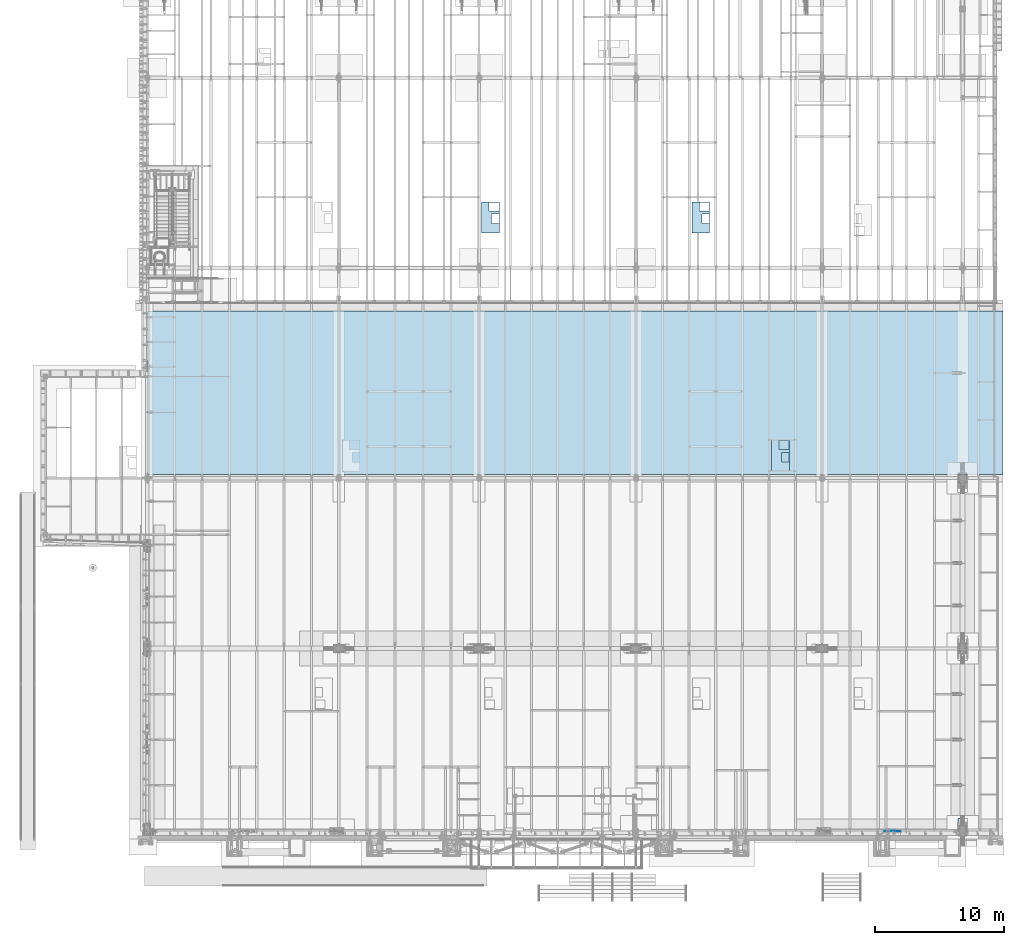
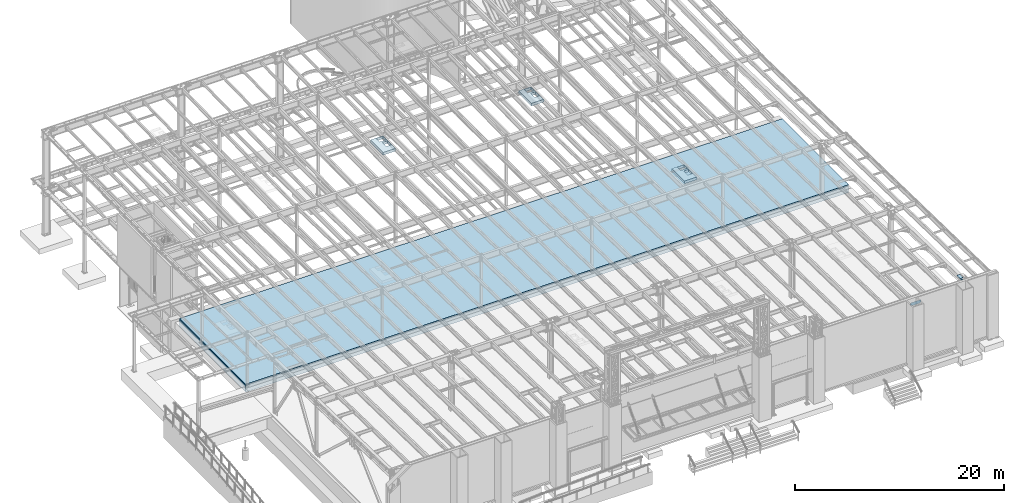
# One storey, part 1414 of 1763: 5 plates, 2 slabs, 7 elements without a shape of their own.
"""IFC2X3 building model written with IfcOpenShell, lengths in millimetres."""

from ifc_helpers import new_model, si_unit, frame, origin_with_axes, place, context, subcontext, project, spatial, faceted_brep, material, type_object, element, aggregate, save


model = new_model("IFC2X3")

# Units and contexts
model_context = context("Model", 3, precision=1e-05, world=origin_with_axes())
body_context = subcontext(model_context, "Body", "Model", "MODEL_VIEW")
ifc_project = project(units=[si_unit("LENGTHUNIT", "METRE", prefix="MILLI"), si_unit("AREAUNIT", "SQUARE_METRE"), si_unit("VOLUMEUNIT", "CUBIC_METRE"), si_unit("MASSUNIT", "GRAM", prefix="KILO"), si_unit("TIMEUNIT", "SECOND"), si_unit("PLANEANGLEUNIT", "RADIAN"), si_unit("SOLIDANGLEUNIT", "STERADIAN"), si_unit("THERMODYNAMICTEMPERATUREUNIT", "DEGREE_CELSIUS"), si_unit("LUMINOUSINTENSITYUNIT", "LUMEN")], contexts=[model_context])

# Site, building, storey
site_placement = place(None, origin_with_axes())
site = spatial("IfcSite", under=ifc_project, at=site_placement, CompositionType="ELEMENT")
building_placement = place(site_placement, origin_with_axes())
building = spatial("IfcBuilding", under=site, at=building_placement, Name="Undefined", CompositionType="ELEMENT")
storey_placement = place(building_placement, origin_with_axes())
storey = spatial("IfcBuildingStorey", under=building, at=storey_placement, Name="Undefined", CompositionType="ELEMENT", Elevation=0.0)

# Assembly, plate
assembly_1_placement = place(storey_placement, origin_with_axes())
assembly_1 = element("IfcElementAssembly", 1, at=assembly_1_placement, inside=storey, Name="B-BOX", AssemblyPlace="NOTDEFINED", PredefinedType="RIGID_FRAME")
ifc_material_1 = material(Name="STEEL/A36")
plate_type_1 = type_object("IfcPlateType", PredefinedType="NOTDEFINED")
plate_1_placement = place(assembly_1_placement, frame((-37492.5957023621, 16646.6066124439, 11747.5), z_axis=(0.0, -1.0, 0.0), x_axis=(-1.0, 0.0, 0.0)))
plate_1 = element("IfcPlate", 2, at=plate_1_placement, type_object=plate_type_1, material=ifc_material_1, Name="B-BOX", context=body_context, shape_type="Brep", body=[
    faceted_brep([(596.899999999994, -152.4, 1691.12592269852), (596.899999999994, 152.4, 1691.12592269852), (596.899999999994, 152.4, 939.803901214145), (596.899999999994, -152.4, 939.803901214145), (44.4499877929629, 152.4, 939.803901214145), (44.4499877929629, -152.4, 939.803901214145), (44.4499877929629, 152.4, 1695.45388175919), (44.4499877929629, -152.4, 1695.45388175919), (596.899999999994, 152.4, 1695.45388175919), (596.899999999994, -152.4, 1695.45388175919), (1377.94995117188, -152.4, 0.0), (0.0, -152.4, 0.0), (0.0, 152.4, 0.0), (1377.94995117188, 152.4, 0.0), (1377.94995117188, -152.4, 2422.52490234375), (1377.94995117188, 152.4, 2422.52490234375), (0.0, -152.4, 2422.52490234375), (0.0, 152.4, 2422.52490234375), (44.4499999999971, -152.4, 44.4499999999971), (44.4500244140654, -152.4, 723.903857421872), (800.091015625003, -152.4, 723.903857421872), (800.091015625003, -152.4, 44.4499999999971), (44.4499999999971, 152.4, 44.4499999999971), (44.4500244140654, 152.4, 723.903857421872), (800.091015625003, 152.4, 44.4499999999971), (800.091015625003, 152.4, 723.903857421872)], [[[0, 1, 2, 3]], [[3, 2, 4, 5]], [[5, 4, 6, 7]], [[7, 6, 8, 9]], [[9, 8, 1, 0]], [[10, 11, 12, 13]], [[14, 10, 13, 15]], [[16, 14, 15, 17]], [[11, 16, 17, 12]], [[10, 14, 16, 11], [3, 5, 7, 9, 0], [18, 19, 20, 21]], [[18, 22, 23, 19]], [[21, 24, 22, 18]], [[20, 25, 24, 21]], [[19, 23, 25, 20]], [[15, 13, 12, 17], [4, 2, 1, 8, 6], [22, 24, 25, 23]]]),
])
aggregate(assembly_1, [plate_1])

assembly_2_placement = place(storey_placement, origin_with_axes())
assembly_2 = element("IfcElementAssembly", 3, at=assembly_2_placement, inside=storey, Name="B-BOX", AssemblyPlace="NOTDEFINED", PredefinedType="RIGID_FRAME")
plate_2_placement = place(assembly_2_placement, frame((-43684.4957084656, 35159.5956566334, 11747.5), z_axis=(0.0, -1.0, 0.0), x_axis=(-1.0, 0.0, 0.0)))
plate_2 = element("IfcPlate", 4, at=plate_2_placement, type_object=plate_type_1, material=ifc_material_1, Name="B-BOX", context=body_context, shape_type="Brep", body=[
    faceted_brep([(596.899999999994, -152.4, 1691.12592269852), (596.899999999994, 152.4, 1691.12592269852), (596.899999999994, 152.4, 939.803901214145), (596.899999999994, -152.4, 939.803901214145), (44.4499877929629, 152.4, 939.803901214145), (44.4499877929629, -152.4, 939.803901214145), (44.4499877929629, 152.4, 1695.45388175919), (44.4499877929629, -152.4, 1695.45388175919), (596.899999999994, 152.4, 1695.45388175919), (596.899999999994, -152.4, 1695.45388175919), (1377.94995117188, -152.4, 0.0), (0.0, -152.4, 0.0), (0.0, 152.4, 0.0), (1377.94995117188, 152.4, 0.0), (1377.94995117188, -152.4, 2422.52490234375), (1377.94995117188, 152.4, 2422.52490234375), (0.0, -152.4, 2422.52490234375), (0.0, 152.4, 2422.52490234375), (44.4499999999971, -152.4, 44.4499999999971), (44.4500244140654, -152.4, 723.903857421872), (800.091015625003, -152.4, 723.903857421872), (800.091015625003, -152.4, 44.4499999999971), (44.4499999999971, 152.4, 44.4499999999971), (44.4500244140654, 152.4, 723.903857421872), (800.091015625003, 152.4, 44.4499999999971), (800.091015625003, 152.4, 723.903857421872)], [[[0, 1, 2, 3]], [[3, 2, 4, 5]], [[5, 4, 6, 7]], [[7, 6, 8, 9]], [[9, 8, 1, 0]], [[10, 11, 12, 13]], [[14, 10, 13, 15]], [[16, 14, 15, 17]], [[11, 16, 17, 12]], [[10, 14, 16, 11], [3, 5, 7, 9, 0], [18, 19, 20, 21]], [[18, 22, 23, 19]], [[21, 24, 22, 18]], [[20, 25, 24, 21]], [[19, 23, 25, 20]], [[15, 13, 12, 17], [4, 2, 1, 8, 6], [22, 24, 25, 23]]]),
])
aggregate(assembly_2, [plate_2])

assembly_3_placement = place(storey_placement, origin_with_axes())
assembly_3 = element("IfcElementAssembly", 5, at=assembly_3_placement, inside=storey, Name="B-BOX", AssemblyPlace="NOTDEFINED", PredefinedType="RIGID_FRAME")
plate_3_placement = place(assembly_3_placement, frame((-60022.8345603943, 35159.5956566334, 11747.5), z_axis=(0.0, -1.0, 0.0), x_axis=(-1.0, 0.0, 0.0)))
plate_3 = element("IfcPlate", 6, at=plate_3_placement, type_object=plate_type_1, material=ifc_material_1, Name="B-BOX", context=body_context, shape_type="Brep", body=[
    faceted_brep([(596.899999999994, -152.4, 1691.12592269852), (596.899999999994, 152.4, 1691.12592269852), (596.899999999994, 152.4, 939.803901214145), (596.899999999994, -152.4, 939.803901214145), (44.4499877929629, 152.4, 939.803901214145), (44.4499877929629, -152.4, 939.803901214145), (44.4499877929629, 152.4, 1695.45388175919), (44.4499877929629, -152.4, 1695.45388175919), (596.899999999994, 152.4, 1695.45388175919), (596.899999999994, -152.4, 1695.45388175919), (1377.94995117188, -152.4, 0.0), (0.0, -152.4, 0.0), (0.0, 152.4, 0.0), (1377.94995117188, 152.4, 0.0), (1377.94995117188, -152.4, 2422.52490234375), (1377.94995117188, 152.4, 2422.52490234375), (0.0, -152.4, 2422.52490234375), (0.0, 152.4, 2422.52490234375), (44.4499999999971, -152.4, 44.4499999999971), (44.4500244140654, -152.4, 723.903857421872), (800.091015625003, -152.4, 723.903857421872), (800.091015625003, -152.4, 44.4499999999971), (44.4499999999971, 152.4, 44.4499999999971), (44.4500244140654, 152.4, 723.903857421872), (800.091015625003, 152.4, 44.4499999999971), (800.091015625003, 152.4, 723.903857421872)], [[[0, 1, 2, 3]], [[3, 2, 4, 5]], [[5, 4, 6, 7]], [[7, 6, 8, 9]], [[9, 8, 1, 0]], [[10, 11, 12, 13]], [[14, 10, 13, 15]], [[16, 14, 15, 17]], [[11, 16, 17, 12]], [[10, 14, 16, 11], [3, 5, 7, 9, 0], [18, 19, 20, 21]], [[18, 22, 23, 19]], [[21, 24, 22, 18]], [[20, 25, 24, 21]], [[19, 23, 25, 20]], [[15, 13, 12, 17], [4, 2, 1, 8, 6], [22, 24, 25, 23]]]),
])
aggregate(assembly_3, [plate_3])

# Assembly, slab
assembly_4_placement = place(storey_placement, origin_with_axes())
assembly_4 = element("IfcElementAssembly", 7, at=assembly_4_placement, inside=storey, Name="SLAB", AssemblyPlace="NOTDEFINED", PredefinedType="REINFORCEMENT_UNIT")
ifc_material_2 = material(Name="CONCRETE/3000")
slab_type_1 = type_object("IfcSlabType", PredefinedType="NOTDEFINED")
slab_1_placement = place(assembly_4_placement, frame((-87375.4372736861, 26670.0, 4806.95), z_axis=(1.0, 0.0, 0.0), x_axis=(0.0, -1.0, 0.0)))
slab_1 = element("IfcSlab", 8, at=slab_1_placement, type_object=slab_type_1, material=ifc_material_2, Name="SLAB", PredefinedType="FLOOR", context=body_context, shape_type="Brep", body=[
    faceted_brep([(0.0, -387.35, 0.0), (0.0, -387.35, 66497.203125), (0.0, 387.35, 66497.203125), (0.0, 387.35, 0.0), (12674.6005859375, -387.35, 66497.203125), (12674.6005859375, 387.35, 66497.203125), (12674.6005859375, -387.35, -1.22381607070565e-08), (12674.6005859375, 387.35, -1.22381607070565e-08)], [[[0, 1, 2, 3]], [[1, 4, 5, 2]], [[4, 6, 7, 5]], [[6, 0, 3, 7]], [[5, 7, 3, 2]], [[6, 4, 1, 0]]]),
])
aggregate(assembly_4, [slab_1])

# Assembly, plate
assembly_5_placement = place(storey_placement, origin_with_axes())
assembly_5 = element("IfcElementAssembly", 9, at=assembly_5_placement, inside=storey, Name="PLATE", AssemblyPlace="NOTDEFINED", PredefinedType="RIGID_FRAME")
ifc_material_3 = material(Name="STEEL/A572-50")
plate_type_2 = type_object("IfcPlateType", PredefinedType="NOTDEFINED")
plate_4_placement = place(assembly_5_placement, frame((-24402.4220768876, -13701.0606507006, 12218.6783026613), z_axis=(0.0, 0.999781542776098, -0.0209013569953182), x_axis=(1.0, 0.0, 0.0)))
plate_4 = element("IfcPlate", 10, at=plate_4_placement, type_object=plate_type_2, material=ifc_material_3, Name="PLATE", context=body_context, shape_type="Brep", body=[
    faceted_brep([(123.824992193364, -14.2875000000113, 3.63797880709171e-12), (123.824992193364, 14.2875000000113, -5.45696821063757e-12), (123.82499219336, 14.287500000104, 285.760002489747), (123.82499219336, -14.2874999999167, 285.760002489757), (127.20854703131, 14.2875000001113, 302.77028135038), (127.20854703131, -14.2874999999112, 302.770281350391), (136.844095993078, 14.287500000115, 317.190899453044), (136.844095993078, -14.2874999999058, 317.190899453055), (151.264714095705, 14.2875000001186, 326.826448414837), (151.264714095705, -14.287499999904, 326.826448414846), (168.274992956296, 14.2875000001204, 330.210003252796), (168.274992956296, -14.2874999999021, 330.210003252805), (346.075022710938, -14.2874999999021, 330.210003252816), (346.075042724609, 14.2875000001204, 330.210003252807), (0.0, -14.2875000000058, 0.0), (-3.63797880709171e-12, -14.2874999997002, 946.190063477328), (-3.63797880709171e-12, 14.2875000003223, 946.190063477319), (0.0, 14.2875000000058, 0.0), (346.075042724609, -14.2874999997002, 946.190063477328), (346.075042724609, 14.2875000003223, 946.190063477319)], [[[0, 1, 2, 3]], [[3, 2, 4, 5]], [[5, 4, 6, 7]], [[7, 6, 8, 9]], [[9, 8, 10, 11]], [[12, 11, 10, 13]], [[14, 15, 16, 17]], [[15, 18, 19, 16]], [[19, 18, 12, 13]], [[8, 6, 4, 2, 1, 17, 16, 19, 13, 10]], [[14, 17, 1, 0]], [[18, 15, 14, 0, 3, 5, 7, 9, 11, 12]]]),
])
aggregate(assembly_5, [plate_4])

assembly_6_placement = place(storey_placement, origin_with_axes())
assembly_6 = element("IfcElementAssembly", 11, at=assembly_6_placement, inside=storey, Name="BEAM", AssemblyPlace="NOTDEFINED", PredefinedType="RIGID_FRAME")
ifc_material_4 = material(Name="STEEL/A572-GR.50")
plate_type_3 = type_object("IfcPlateType", PredefinedType="NOTDEFINED")
plate_5_placement = place(assembly_6_placement, frame((-28923.4769907772, -13716.0, 11544.2999999991), z_axis=(0.0, 0.0, -1.0), x_axis=(-1.0, 0.0, 0.0)))
plate_5 = element("IfcPlate", 12, at=plate_5_placement, type_object=plate_type_3, material=ifc_material_4, Name="PLATE", context=body_context, shape_type="Brep", body=[
    faceted_brep([(0.0, -9.52500000000146, 0.0), (-32.5954780578613, -9.52499999999964, 213.365493774414), (-32.5954780578613, 9.52499999999964, 213.365493774414), (0.0, 9.52500000000146, 0.0), (165.91081237793, -9.52499999999964, 372.318389892578), (165.91081237793, 9.52499999999964, 372.318389892578), (970.835510253906, -9.52499999999964, 372.318389892578), (970.835510253906, 9.52499999999964, 372.318389892578), (1168.22973632812, -9.52499999999964, 212.469955444336), (1168.22973632812, 9.52499999999964, 212.469955444336), (1134.57666015625, -9.52499999999964, 0.0), (1134.57666015625, 9.52499999999964, 0.0)], [[[0, 1, 2, 3]], [[1, 4, 5, 2]], [[4, 6, 7, 5]], [[6, 8, 9, 7]], [[8, 10, 11, 9]], [[10, 0, 3, 11]], [[5, 7, 9, 11, 3, 2]], [[10, 8, 6, 4, 1, 0]]]),
])
aggregate(assembly_6, [plate_5])

# Assembly, slab
assembly_7_placement = place(storey_placement, origin_with_axes())
assembly_7 = element("IfcElementAssembly", 13, at=assembly_7_placement, inside=storey, Name="SLAB", AssemblyPlace="NOTDEFINED", PredefinedType="REINFORCEMENT_UNIT")
slab_type_2 = type_object("IfcSlabType", PredefinedType="NOTDEFINED")
slab_2_placement = place(assembly_7_placement, frame((-87375.4372736861, 26670.0, 5264.15), z_axis=(1.0, 0.0, 0.0), x_axis=(0.0, -1.0, 0.0)))
slab_2 = element("IfcSlab", 14, at=slab_2_placement, type_object=slab_type_2, material=ifc_material_2, Name="SLAB", PredefinedType="FLOOR", context=body_context, shape_type="Brep", body=[
    faceted_brep([(0.0, -69.8500000000004, 0.0), (0.0, -69.8500000000004, 66497.203125), (0.0, 69.8500000000004, 66497.203125), (0.0, 69.8500000000004, 0.0), (12674.6005859375, -69.8500000000004, 66497.203125), (12674.6005859375, 69.8500000000004, 66497.203125), (12674.6005859375, -69.8500000000004, -1.22381607070565e-08), (12674.6005859375, 69.8500000000004, -1.22381607070565e-08)], [[[0, 1, 2, 3]], [[1, 4, 5, 2]], [[4, 6, 7, 5]], [[6, 0, 3, 7]], [[5, 7, 3, 2]], [[6, 4, 1, 0]]]),
])
aggregate(assembly_7, [slab_2])

save(model, "model.ifc")
